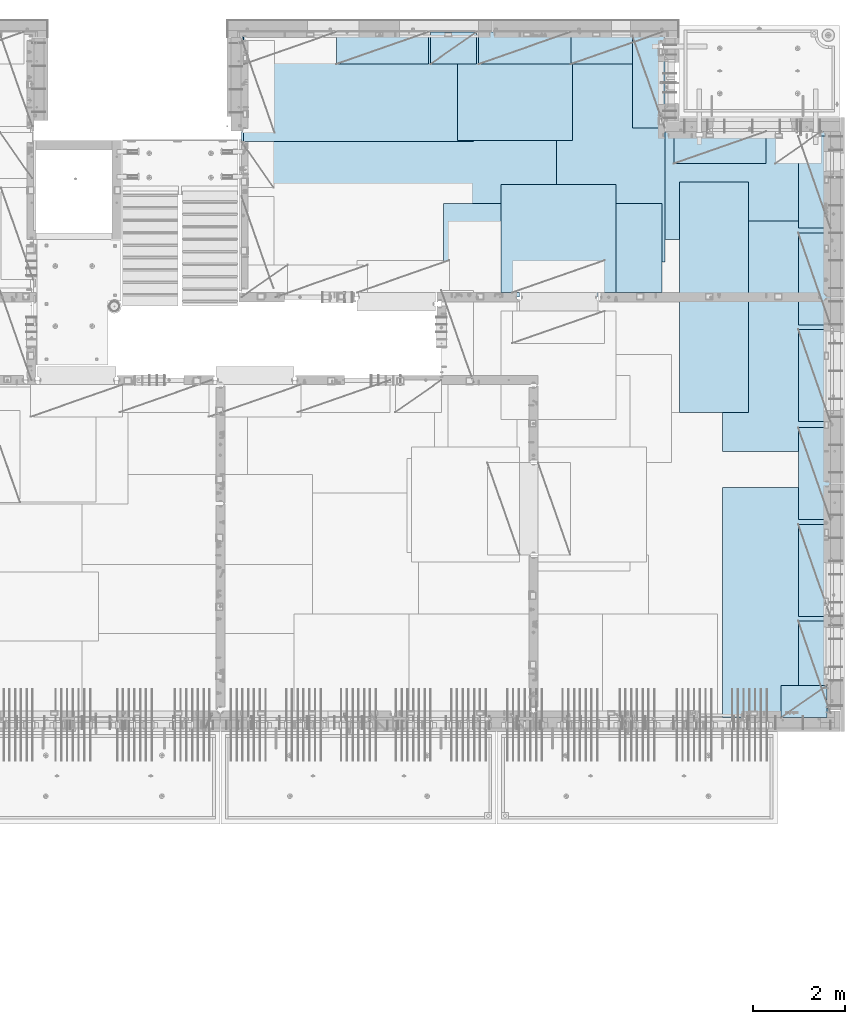
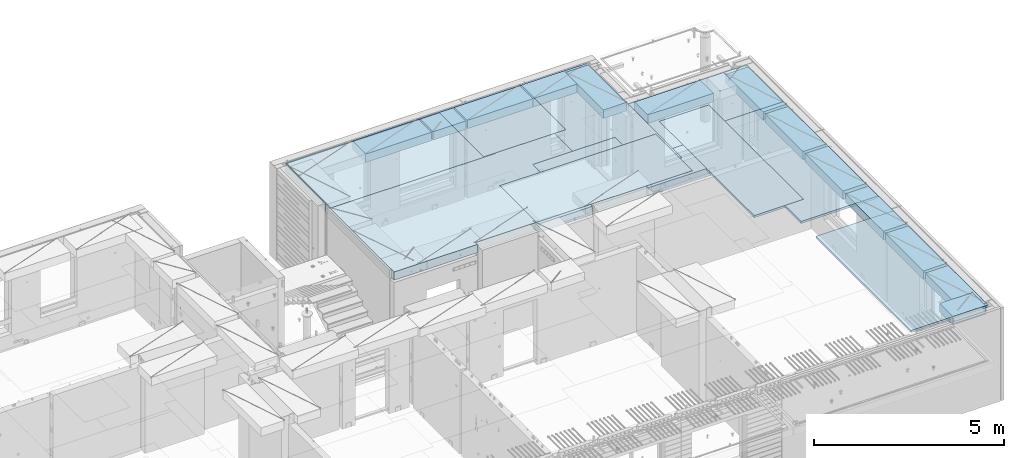
# One storey, part 201 of 334: 22 plates, 1 slab, 22 elements without a shape of their own.
"""IFC2X3 building model written with IfcOpenShell, lengths in millimetres."""

import ifcopenshell
import ifcopenshell.guid

model = None  # the IFC model being written
_history = None  # IfcOwnerHistory: only IFC2X3 demands one
_inside = {}  # id of a spatial element -> (the spatial element, [elements in it])
_under = {}  # id of a project, library or spatial element -> (it, [spatial elements below it])
_declared = {}  # id of a project -> (the project, [libraries it declares])
_typed = {}  # id of a type object -> (the type object, [elements of that type])
_made_of = {}  # id of a material, layer set ... -> (it, [elements and type objects made of it])


def new_model(schema):
    """Start an empty IFC model of exactly this schema.

    Asked for "IFC4X3", IfcOpenShell would pick the latest addendum, in which some entities
    have other attributes; the version numbers below select the first issue.
    IFC2X3 requires an IfcOwnerHistory on every rooted entity: one is made here for all.
    """
    global model, _history
    if schema == "IFC4X3":
        model = ifcopenshell.file(schema_version=(4, 3, 0, 0))
    else:
        model = ifcopenshell.file(schema=schema)
    _inside.clear()
    _under.clear()
    _declared.clear()
    _typed.clear()
    _made_of.clear()
    _history = None
    if model.schema == "IFC2X3":
        org = make("IfcOrganization", Name="unknown")
        user = make(
            "IfcPersonAndOrganization",
            ThePerson=make("IfcPerson", FamilyName="unknown"),
            TheOrganization=org,
        )
        app = make(
            "IfcApplication",
            ApplicationDeveloper=org,
            Version="unknown",
            ApplicationFullName="unknown",
            ApplicationIdentifier="unknown",
        )
        _history = make(
            "IfcOwnerHistory",
            OwningUser=user,
            OwningApplication=app,
            ChangeAction="ADDED",
            CreationDate=0,
        )
    return model


def make(cls, **values):
    """One entity of the class cls with the attributes given. An attribute that is None is left unset."""
    return model.create_entity(
        cls, **{name: value for name, value in values.items() if value is not None}
    )


def rooted(cls, **values):
    """An entity with a GlobalId (a new one), such as an element, a storey or a relation."""
    return make(cls, GlobalId=ifcopenshell.guid.new(), OwnerHistory=_history, **values)


def si_unit(unit_type, name, prefix=None):
    """IfcSIUnit, for example si_unit("LENGTHUNIT", "METRE", prefix="MILLI")."""
    return make("IfcSIUnit", UnitType=unit_type, Prefix=prefix, Name=name)


def assignment(units):
    """IfcUnitAssignment: the units of a project."""
    return None if units is None else make("IfcUnitAssignment", Units=units)


def point(xyz):
    """IfcCartesianPoint."""
    return None if xyz is None else make("IfcCartesianPoint", Coordinates=xyz)


def direction(xyz):
    """IfcDirection."""
    return None if xyz is None else make("IfcDirection", DirectionRatios=xyz)


def frame(location, z_axis=None, x_axis=None):
    """IfcAxis2Placement3D, a coordinate frame: its origin and axes. An axis left out is left unset."""
    return make(
        "IfcAxis2Placement3D",
        Location=point(location),
        Axis=direction(z_axis),
        RefDirection=direction(x_axis),
    )


def origin_with_axes():
    """The frame at (0, 0, 0) with the z axis (0, 0, 1) and the x axis (1, 0, 0) written out."""
    return frame((0.0, 0.0, 0.0), z_axis=(0.0, 0.0, 1.0), x_axis=(1.0, 0.0, 0.0))


def place(relative_to, where):
    """IfcLocalPlacement: puts the frame where relative to a parent placement (None: the world)."""
    return make(
        "IfcLocalPlacement", PlacementRelTo=relative_to, RelativePlacement=where
    )


def context(
    kind, dimensions, precision=None, world=None, true_north=None, identifier=None
):
    """IfcGeometricRepresentationContext, for example the 3D "Model" context."""
    return make(
        "IfcGeometricRepresentationContext",
        ContextIdentifier=identifier,
        ContextType=kind,
        CoordinateSpaceDimension=dimensions,
        Precision=precision,
        WorldCoordinateSystem=world,
        TrueNorth=true_north,
    )


def subcontext(parent, identifier, kind, view, scale=None):
    """IfcGeometricRepresentationSubContext, for example "Body" below "Model"."""
    return make(
        "IfcGeometricRepresentationSubContext",
        ContextIdentifier=identifier,
        ContextType=kind,
        ParentContext=parent,
        TargetScale=scale,
        TargetView=view,
    )


def project(units=None, contexts=None):
    """IfcProject with its units and contexts."""
    return rooted(
        "IfcProject",
        Name="project",
        RepresentationContexts=contexts,
        UnitsInContext=assignment(units),
    )


def spatial(cls, under=None, at=None, **own):
    """A site, building, storey or space (cls), placed at a placement, below another one or the project."""
    s = rooted(cls, ObjectPlacement=at, **own)
    if under is not None:
        _under.setdefault(under.id(), (under, []))[1].append(s)
    return s


def faces_of(points, faces, orient=None, outer=None):
    """IfcFace entities. A face is a list of loops; a loop is a list of indices into points, from 0.

    orient and outer hold one flag for each loop. By default every Orientation is true, the
    first loop of a face is its IfcFaceOuterBound and the others are IfcFaceBound.
    """
    made = []
    for i, loops in enumerate(faces):
        bounds = []
        for j, loop in enumerate(loops):
            is_outer = j == 0 if outer is None else outer[i][j]
            bounds.append(
                make(
                    "IfcFaceOuterBound" if is_outer else "IfcFaceBound",
                    Bound=make("IfcPolyLoop", Polygon=[points[k] for k in loop]),
                    Orientation=True if orient is None else orient[i][j],
                )
            )
        made.append(make("IfcFace", Bounds=bounds))
    return made


def faceted_brep(points, faces, orient=None, outer=None, voids=None):
    """IfcFacetedBrep: a solid bounded by flat faces; with voids (closed shells), ...WithVoids."""
    shared = [point(p) for p in points]
    hull = make("IfcClosedShell", CfsFaces=faces_of(shared, faces, orient, outer))
    if voids is None:
        return make("IfcFacetedBrep", Outer=hull)
    return make(
        "IfcFacetedBrepWithVoids",
        Outer=hull,
        Voids=[
            make(cls, CfsFaces=faces_of(shared, fs, o, b)) for cls, fs, o, b in voids
        ],
    )


def shape(context_of_items, identifier, shape_type, items):
    """IfcShapeRepresentation: the items that make up one representation, for example the "Body"."""
    return make(
        "IfcShapeRepresentation",
        ContextOfItems=context_of_items,
        RepresentationIdentifier=identifier,
        RepresentationType=shape_type,
        Items=items,
    )


def material(Name=None, Category=None):
    """IfcMaterial."""
    return make("IfcMaterial", Name=Name, Category=Category)


def made_of(thing, what):
    """Note that an element or type object is made of a material, layer set ...; save() writes the relation."""
    if what is not None:
        _made_of.setdefault(what.id(), (what, []))[1].append(thing)
    return thing


def type_object(cls, material=None, **own):
    """A type object (cls), such as IfcWallType, which elements share."""
    return made_of(rooted(cls, **own), material)


def element(
    cls,
    number,
    at=None,
    inside=None,
    cuts=None,
    type_object=None,
    material=None,
    context=None,
    identifier="Body",
    shape_type=None,
    held_by="IfcProductDefinitionShape",
    body=None,
    shapes=None,
    **own,
):
    """One element of the class cls, such as IfcWall. Its Tag is "e" and its number.

    at: its placement. inside: the storey or other place that contains it. cuts: it is an
    opening in that element (IfcRelVoidsElement). A single representation is given by context,
    identifier, shape_type and body (its items); several are given by shapes. held_by: the class
    of the entity that holds the representations. save() writes the other relations.
    """
    e = rooted(cls, Tag="e%d" % number, ObjectPlacement=at, **own)
    if body is not None:
        shapes = [shape(context, identifier, shape_type, body)]
    if shapes is not None:
        e.Representation = make(held_by, Representations=shapes)
    if inside is not None:
        _inside.setdefault(inside.id(), (inside, []))[1].append(e)
    if cuts is not None:
        rooted(
            "IfcRelVoidsElement", RelatingBuildingElement=cuts, RelatedOpeningElement=e
        )
    if type_object is not None:
        _typed.setdefault(type_object.id(), (type_object, []))[1].append(e)
    return made_of(e, material)


def aggregate(whole, parts):
    """IfcRelAggregates: a whole, such as a stair, and the parts it consists of."""
    return rooted("IfcRelAggregates", RelatingObject=whole, RelatedObjects=parts)


def save(model, path):
    """Write the relations noted so far, then the file.

    IfcRelAggregates (storeys below a building ...), IfcRelContainedInSpatialStructure (elements
    in a storey), IfcRelDefinesByType, IfcRelAssociatesMaterial and IfcRelDeclares: one each for
    every whole, place, type object, material and project.
    """
    for whole, parts in _under.values():
        aggregate(whole, parts)
    for where, things in _inside.values():
        rooted(
            "IfcRelContainedInSpatialStructure",
            RelatedElements=things,
            RelatingStructure=where,
        )
    for kind, things in _typed.values():
        rooted("IfcRelDefinesByType", RelatedObjects=things, RelatingType=kind)
    for what, things in _made_of.values():
        rooted("IfcRelAssociatesMaterial", RelatedObjects=things, RelatingMaterial=what)
    for by, libraries in _declared.values():
        rooted("IfcRelDeclares", RelatingContext=by, RelatedDefinitions=libraries)
    model.write(path)


model = new_model("IFC2X3")

# Units and contexts
model_context = context("Model", 3, precision=1e-05, world=origin_with_axes())
body_context = subcontext(model_context, "Body", "Model", "MODEL_VIEW")
ifc_project = project(units=[si_unit("LENGTHUNIT", "METRE", prefix="MILLI"), si_unit("AREAUNIT", "SQUARE_METRE"), si_unit("VOLUMEUNIT", "CUBIC_METRE"), si_unit("MASSUNIT", "GRAM", prefix="KILO"), si_unit("TIMEUNIT", "SECOND"), si_unit("PLANEANGLEUNIT", "RADIAN"), si_unit("SOLIDANGLEUNIT", "STERADIAN"), si_unit("THERMODYNAMICTEMPERATUREUNIT", "DEGREE_CELSIUS"), si_unit("LUMINOUSINTENSITYUNIT", "LUMEN")], contexts=[model_context])

# Site, building, storey
site_placement = place(None, origin_with_axes())
site = spatial("IfcSite", under=ifc_project, at=site_placement, CompositionType="ELEMENT")
building_placement = place(site_placement, origin_with_axes())
building = spatial("IfcBuilding", under=site, at=building_placement, CompositionType="ELEMENT")
storey_placement = place(building_placement, origin_with_axes())
storey = spatial("IfcBuildingStorey", under=building, at=storey_placement, Name="3", CompositionType="ELEMENT", Elevation=0.0)

# Assembly, slab
assembly_1_placement = place(storey_placement, origin_with_axes())
assembly_1 = element("IfcElementAssembly", 1, at=assembly_1_placement, inside=storey, AssemblyPlace="NOTDEFINED", PredefinedType="REINFORCEMENT_UNIT")
ifc_material_1 = material(Name="CONCRETE/C30/37")
slab_type = type_object("IfcSlabType", PredefinedType="NOTDEFINED")
slab_placement = place(assembly_1_placement, frame((22310.0, 16980.0, 90595.0), z_axis=(0.0, 1.0, 0.0), x_axis=(1.0, 0.0, 0.0)))
slab = element("IfcSlab", 2, at=slab_placement, type_object=slab_type, material=ifc_material_1, PredefinedType="FLOOR", context=body_context, shape_type="Brep", body=[
    faceted_brep([(2489.99914550781, -135.0, 0.0), (2489.99914550781, 135.0, 0.0), (2489.99914550781, 135.0, 99.9997253417969), (2489.99914550781, -135.0, 99.9997253417969), (2730.00000000001, -135.0, 99.9999987875526), (2730.00000000001, 135.0, 99.9999987875526), (1.81898940354586e-12, -135.0, 1.81898940354586e-12), (-39.9985427856445, -135.0, -0.0037095642182976), (-39.9985427856445, 135.0, -0.0037095642182976), (1.81898940354586e-12, 135.0, 1.81898940354586e-12), (-40.0, -135.0, 3600.00048828125), (-40.0, 135.0, 3600.00048828125), (-20.0, -135.0, 3600.0), (-20.0, 135.0, 3600.0), (-20.0, -135.0, 5760.0), (-20.0, 135.0, 5760.0), (9149.9990234375, -135.0, 5760.0), (9149.9990234375, 135.0, 5760.0), (9149.9990234375, -135.0, 3600.00073242188), (9149.9990234375, 135.0, 3600.00073242188), (12750.0, -135.0, 3599.9951171875), (12750.0, 135.0, 3599.9951171875), (12750.0, -135.0, 0.0), (12750.0, 135.0, 0.0), (7685.00027673977, -135.0, 0.0), (7685.00027673977, 135.0, 0.0), (7685.00027673977, -135.0, 99.9997241293495), (7685.00027673977, 135.0, 99.9997241293495), (6000.00027673977, -135.0, 99.9997241293495), (6000.00027673977, 135.0, 99.9997241293495), (6000.00027673977, -135.0, 0.0), (6000.00027673977, 135.0, 0.0), (4369.99914550782, -135.0, 0.0), (4369.99914550782, 135.0, 0.0), (4369.99914550782, -135.0, 99.9999987875526), (4369.99914550782, 135.0, 99.9999987875526), (4169.99914550781, -135.0, 99.9999987875526), (4169.99914550781, 135.0, 99.9999987875526)], [[[0, 1, 2, 3]], [[4, 3, 2, 5]], [[6, 7, 8, 9]], [[7, 10, 11, 8]], [[10, 12, 13, 11]], [[12, 14, 15, 13]], [[14, 16, 17, 15]], [[16, 18, 19, 17]], [[18, 20, 21, 19]], [[20, 22, 23, 21]], [[23, 22, 24, 25]], [[26, 27, 25, 24]], [[28, 29, 27, 26]], [[30, 31, 29, 28]], [[31, 30, 32, 33]], [[34, 35, 33, 32]], [[36, 4, 5, 37, 35, 34]], [[1, 9, 8, 11, 13, 15, 17, 19, 21, 23, 25, 27, 29, 31, 33, 35, 37, 5, 2]], [[6, 9, 1, 0]], [[36, 34, 32, 30, 28, 26, 24, 22, 20, 18, 16, 14, 12, 10, 7, 6, 0, 3, 4]]]),
])

# Assembly, plate
assembly_2_placement = place(storey_placement, origin_with_axes())
assembly_2 = element("IfcElementAssembly", 3, at=assembly_2_placement, inside=storey, Name="Steel Assembly", AssemblyPlace="NOTDEFINED", PredefinedType="NOTDEFINED")
ifc_material_2 = material()
plate_type_1 = type_object("IfcPlateType", PredefinedType="NOTDEFINED")
plate_1_placement = place(assembly_2_placement, frame((26960.07, 22728.45, 90695.1), z_axis=(1.0, 0.0, 0.0), x_axis=(0.0, -1.0, 0.0)))
plate_1 = element("IfcPlate", 4, at=plate_1_placement, type_object=plate_type_1, material=ifc_material_2, Name="1/2", context=body_context, shape_type="Brep", body=[
    faceted_brep([(0.0, -35.0, 0.0), (0.0, -35.0, 2500.0), (0.0, 35.0, 2500.0), (0.0, 35.0, 0.0), (2349.99951171875, -35.0, 2500.0), (2349.99951171875, 35.0, 2500.0), (2350.0, -35.0, 0.0), (2350.0, 35.0, 0.0)], [[[0, 1, 2, 3]], [[1, 4, 5, 2]], [[4, 6, 7, 5]], [[6, 0, 3, 7]], [[5, 7, 3, 2]], [[6, 4, 1, 0]]]),
])
aggregate(assembly_2, [plate_1])

assembly_3_placement = place(storey_placement, origin_with_axes())
assembly_3 = element("IfcElementAssembly", 5, at=assembly_3_placement, inside=storey, Name="Steel Assembly", AssemblyPlace="NOTDEFINED", PredefinedType="NOTDEFINED")
plate_2_placement = place(assembly_3_placement, frame((22309.9998779297, 22710.0009765625, 90695.1), z_axis=(1.0, 0.0, 0.0), x_axis=(0.0, -1.0, 0.0)))
plate_2 = element("IfcPlate", 6, at=plate_2_placement, type_object=plate_type_1, material=ifc_material_2, context=body_context, shape_type="Brep", body=[
    faceted_brep([(0.0, -35.0, 0.0), (0.0, -35.0, 5000.0), (0.0, 35.0, 5000.0), (0.0, 35.0, 0.0), (2349.99951171875, -35.0, 5000.0), (2349.99951171875, 35.0, 5000.0), (2350.0, -35.0, 0.0), (2350.0, 35.0, 0.0)], [[[0, 1, 2, 3]], [[1, 4, 5, 2]], [[4, 6, 7, 5]], [[6, 0, 3, 7]], [[5, 7, 3, 2]], [[6, 4, 1, 0]]]),
])
aggregate(assembly_3, [plate_2])

assembly_4_placement = place(storey_placement, origin_with_axes())
assembly_4 = element("IfcElementAssembly", 7, at=assembly_4_placement, inside=storey, Name="Steel Assembly", AssemblyPlace="NOTDEFINED", PredefinedType="NOTDEFINED")
plate_3_placement = place(assembly_4_placement, frame((27902.5, 19430.0, 90695.1), z_axis=(1.0, 0.0, 0.0), x_axis=(0.0, -1.0, 0.0)))
plate_3 = element("IfcPlate", 8, at=plate_3_placement, type_object=plate_type_1, material=ifc_material_2, Name="1/2", context=body_context, shape_type="Brep", body=[
    faceted_brep([(0.0, -35.0, 0.0), (0.0, -35.0, 2500.0), (0.0, 35.0, 2500.0), (0.0, 35.0, 0.0), (2349.99951171875, -35.0, 2500.0), (2349.99951171875, 35.0, 2500.0), (2350.0, -35.0, 0.0), (2350.0, 35.0, 0.0)], [[[0, 1, 2, 3]], [[1, 4, 5, 2]], [[4, 6, 7, 5]], [[6, 0, 3, 7]], [[5, 7, 3, 2]], [[6, 4, 1, 0]]]),
])
aggregate(assembly_4, [plate_3])

assembly_5_placement = place(storey_placement, origin_with_axes())
assembly_5 = element("IfcElementAssembly", 9, at=assembly_5_placement, inside=storey, Name="Steel Assembly", AssemblyPlace="NOTDEFINED", PredefinedType="NOTDEFINED")
plate_4_placement = place(assembly_5_placement, frame((31460.0, 22740.0, 90695.1), z_axis=(0.0, -1.0, 0.0), x_axis=(-1.0, 3.00000001838171e-08, 0.0)))
plate_4 = element("IfcPlate", 10, at=plate_4_placement, type_object=plate_type_1, material=ifc_material_2, context=body_context, shape_type="Brep", body=[
    faceted_brep([(0.0, -35.0, 0.0), (0.0, -35.0, 5000.0), (0.0, 35.0, 5000.0), (0.0, 35.0, 0.0), (2349.99951171875, -35.0, 5000.0), (2349.99951171875, 35.0, 5000.0), (2350.0, -35.0, 0.0), (2350.0, 35.0, 0.0)], [[[0, 1, 2, 3]], [[1, 4, 5, 2]], [[4, 6, 7, 5]], [[6, 0, 3, 7]], [[5, 7, 3, 2]], [[6, 4, 1, 0]]]),
])
aggregate(assembly_5, [plate_4])

assembly_6_placement = place(storey_placement, origin_with_axes())
assembly_6 = element("IfcElementAssembly", 11, at=assembly_6_placement, inside=storey, Name="Steel Assembly", AssemblyPlace="NOTDEFINED", PredefinedType="NOTDEFINED")
plate_5_placement = place(assembly_6_placement, frame((35060.0, 12850.0, 90695.1), z_axis=(0.0, -1.0, 0.0), x_axis=(-1.0, 3.00000001838171e-08, 0.0)))
plate_5 = element("IfcPlate", 12, at=plate_5_placement, type_object=plate_type_1, material=ifc_material_2, context=body_context, shape_type="Brep", body=[
    faceted_brep([(0.0, -35.0, 0.0), (0.0, -35.0, 5000.0), (0.0, 35.0, 5000.0), (0.0, 35.0, 0.0), (2349.99951171875, -35.0, 5000.0), (2349.99951171875, 35.0, 5000.0), (2350.0, -35.0, 0.0), (2350.0, 35.0, 0.0)], [[[0, 1, 2, 3]], [[1, 4, 5, 2]], [[4, 6, 7, 5]], [[6, 0, 3, 7]], [[5, 7, 3, 2]], [[6, 4, 1, 0]]]),
])
aggregate(assembly_6, [plate_5])

assembly_7_placement = place(storey_placement, origin_with_axes())
assembly_7 = element("IfcElementAssembly", 13, at=assembly_7_placement, inside=storey, Name="Steel Assembly", AssemblyPlace="NOTDEFINED", PredefinedType="NOTDEFINED")
plate_6_placement = place(assembly_7_placement, frame((35060.0, 18630.0, 90695.1), z_axis=(0.0, -1.0, 0.0), x_axis=(-1.0, 3.00000001838171e-08, 0.0)))
plate_6 = element("IfcPlate", 14, at=plate_6_placement, type_object=plate_type_1, material=ifc_material_2, context=body_context, shape_type="Brep", body=[
    faceted_brep([(0.0, -35.0, 0.0), (0.0, -35.0, 5000.0), (0.0, 35.0, 5000.0), (0.0, 35.0, 0.0), (2349.99951171875, -35.0, 5000.0), (2349.99951171875, 35.0, 5000.0), (2350.0, -35.0, 0.0), (2350.0, 35.0, 0.0)], [[[0, 1, 2, 3]], [[1, 4, 5, 2]], [[4, 6, 7, 5]], [[6, 0, 3, 7]], [[5, 7, 3, 2]], [[6, 4, 1, 0]]]),
])
aggregate(assembly_7, [plate_6])

assembly_8_placement = place(storey_placement, origin_with_axes())
assembly_8 = element("IfcElementAssembly", 15, at=assembly_8_placement, inside=storey, Name="Steel Assembly", AssemblyPlace="NOTDEFINED", PredefinedType="NOTDEFINED")
plate_7_placement = place(assembly_8_placement, frame((30060.0, 20580.0, 90695.1), z_axis=(1.0, 0.0, 0.0), x_axis=(0.0, -1.0, 0.0)))
plate_7 = element("IfcPlate", 16, at=plate_7_placement, type_object=plate_type_1, material=ifc_material_2, context=body_context, shape_type="Brep", body=[
    faceted_brep([(0.0, -35.0, 0.0), (0.0, -35.0, 5000.0), (0.0, 35.0, 5000.0), (0.0, 35.0, 0.0), (2349.99951171875, -35.0, 5000.0), (2349.99951171875, 35.0, 5000.0), (2350.0, -35.0, 0.0), (2350.0, 35.0, 0.0)], [[[0, 1, 2, 3]], [[1, 4, 5, 2]], [[4, 6, 7, 5]], [[6, 0, 3, 7]], [[5, 7, 3, 2]], [[6, 4, 1, 0]]]),
])
aggregate(assembly_8, [plate_7])

assembly_9_placement = place(storey_placement, origin_with_axes())
assembly_9 = element("IfcElementAssembly", 17, at=assembly_9_placement, inside=storey, Name="Steel Assembly", AssemblyPlace="NOTDEFINED", PredefinedType="NOTDEFINED")
plate_type_2 = type_object("IfcPlateType", PredefinedType="NOTDEFINED")
plate_8_placement = place(assembly_9_placement, frame((33275.0000122641, 19480.0, 90695.1000003815), z_axis=(0.0, -1.0, 0.0), x_axis=(-1.0, 3.00000001838171e-08, 0.0)))
plate_8 = element("IfcPlate", 18, at=plate_8_placement, type_object=plate_type_2, material=ifc_material_2, context=body_context, shape_type="Brep", body=[
    faceted_brep([(0.0, -35.0, 0.0), (0.0, -35.0, 5000.0), (0.0, 35.0, 5000.0), (0.0, 35.0, 0.0), (1499.99951171875, -35.0, 5000.0), (1499.99951171875, 35.0, 5000.0), (1500.0, -35.0, 0.0), (1500.0, 35.0, 0.0)], [[[0, 1, 2, 3]], [[1, 4, 5, 2]], [[4, 6, 7, 5]], [[6, 0, 3, 7]], [[5, 7, 3, 2]], [[6, 4, 1, 0]]]),
])
aggregate(assembly_9, [plate_8])

assembly_10_placement = place(storey_placement, origin_with_axes())
assembly_10 = element("IfcElementAssembly", 19, at=assembly_10_placement, inside=storey, Name="Steel Assembly", AssemblyPlace="NOTDEFINED", PredefinedType="NOTDEFINED")
plate_type_3 = type_object("IfcPlateType", PredefinedType="NOTDEFINED")
plate_9_placement = place(assembly_10_placement, frame((31420.0, 22740.0001220703, 90595.3), z_axis=(0.0, -1.0, 0.0), x_axis=(-1.0, 3.00000001838171e-08, 0.0)))
plate_9 = element("IfcPlate", 20, at=plate_9_placement, type_object=plate_type_3, material=ifc_material_2, Name="RE1", context=body_context, shape_type="Brep", body=[
    faceted_brep([(1.81898940354586e-12, -135.0, 1.81898940354586e-12), (0.0, -135.0, 699.999999999996), (0.0, 135.0, 699.999999999996), (1.81898940354586e-12, 135.0, 1.81898940354586e-12), (1999.99951171875, -135.0, 699.999999999993), (1999.99951171875, 135.0, 699.999999999993), (2000.0, -135.0, -3.63797880709171e-12), (2000.0, 135.0, -3.63797880709171e-12)], [[[0, 1, 2, 3]], [[1, 4, 5, 2]], [[4, 6, 7, 5]], [[6, 0, 3, 7]], [[5, 7, 3, 2]], [[6, 4, 1, 0]]]),
])
aggregate(assembly_10, [plate_9])

assembly_11_placement = place(storey_placement, origin_with_axes())
assembly_11 = element("IfcElementAssembly", 21, at=assembly_11_placement, inside=storey, Name="Steel Assembly", AssemblyPlace="NOTDEFINED", PredefinedType="NOTDEFINED")
plate_10_placement = place(assembly_11_placement, frame((33985.0, 7849.99999992931, 90595.3), z_axis=(0.0, 1.0, 0.0), x_axis=(1.0, 0.0, 0.0)))
plate_10 = element("IfcPlate", 22, at=plate_10_placement, type_object=plate_type_3, material=ifc_material_2, Name="RE1_1/2", context=body_context, shape_type="Brep", body=[
    faceted_brep([(1.81898940354586e-12, -135.0, 1.81898940354586e-12), (0.0, -135.0, 699.999999999996), (0.0, 135.0, 699.999999999996), (1.81898940354586e-12, 135.0, 1.81898940354586e-12), (999.99951171875, -135.0, 700.0), (999.99951171875, 135.0, 700.0), (1000.0, -135.0, 0.0), (1000.0, 135.0, 0.0)], [[[0, 1, 2, 3]], [[1, 4, 5, 2]], [[4, 6, 7, 5]], [[6, 0, 3, 7]], [[5, 7, 3, 2]], [[6, 4, 1, 0]]]),
])
aggregate(assembly_11, [plate_10])

assembly_12_placement = place(storey_placement, origin_with_axes())
assembly_12 = element("IfcElementAssembly", 23, at=assembly_12_placement, inside=storey, Name="Steel Assembly", AssemblyPlace="NOTDEFINED", PredefinedType="NOTDEFINED")
plate_11_placement = place(assembly_12_placement, frame((35060.0001220703, 14280.0, 90595.3), z_axis=(-1.0, 3.00000001838171e-08, 0.0), x_axis=(0.0, 1.0, 0.0)))
plate_11 = element("IfcPlate", 24, at=plate_11_placement, type_object=plate_type_3, material=ifc_material_2, Name="RE1", context=body_context, shape_type="Brep", body=[
    faceted_brep([(1.81898940354586e-12, -135.0, 1.81898940354586e-12), (0.0, -135.0, 699.999999999996), (0.0, 135.0, 699.999999999996), (1.81898940354586e-12, 135.0, 1.81898940354586e-12), (1999.99951171875, -135.0, 699.999999999993), (1999.99951171875, 135.0, 699.999999999993), (2000.0, -135.0, -3.63797880709171e-12), (2000.0, 135.0, -3.63797880709171e-12)], [[[0, 1, 2, 3]], [[1, 4, 5, 2]], [[4, 6, 7, 5]], [[6, 0, 3, 7]], [[5, 7, 3, 2]], [[6, 4, 1, 0]]]),
])
aggregate(assembly_12, [plate_11])

assembly_13_placement = place(storey_placement, origin_with_axes())
assembly_13 = element("IfcElementAssembly", 25, at=assembly_13_placement, inside=storey, Name="Steel Assembly", AssemblyPlace="NOTDEFINED", PredefinedType="NOTDEFINED")
plate_12_placement = place(assembly_13_placement, frame((35060.0001220703, 16380.0, 90595.3), z_axis=(-1.0, 3.00000001838171e-08, 0.0), x_axis=(0.0, 1.0, 0.0)))
plate_12 = element("IfcPlate", 26, at=plate_12_placement, type_object=plate_type_3, material=ifc_material_2, Name="RE1", context=body_context, shape_type="Brep", body=[
    faceted_brep([(1.81898940354586e-12, -135.0, 1.81898940354586e-12), (0.0, -135.0, 699.999999999996), (0.0, 135.0, 699.999999999996), (1.81898940354586e-12, 135.0, 1.81898940354586e-12), (1999.99951171875, -135.0, 699.999999999993), (1999.99951171875, 135.0, 699.999999999993), (2000.0, -135.0, -3.63797880709171e-12), (2000.0, 135.0, -3.63797880709171e-12)], [[[0, 1, 2, 3]], [[1, 4, 5, 2]], [[4, 6, 7, 5]], [[6, 0, 3, 7]], [[5, 7, 3, 2]], [[6, 4, 1, 0]]]),
])
aggregate(assembly_13, [plate_12])

assembly_14_placement = place(storey_placement, origin_with_axes())
assembly_14 = element("IfcElementAssembly", 27, at=assembly_14_placement, inside=storey, Name="Steel Assembly", AssemblyPlace="NOTDEFINED", PredefinedType="NOTDEFINED")
plate_13_placement = place(assembly_14_placement, frame((35060.0001220703, 18480.0, 90595.3), z_axis=(-1.0, 3.00000001838171e-08, 0.0), x_axis=(0.0, 1.0, 0.0)))
plate_13 = element("IfcPlate", 28, at=plate_13_placement, type_object=plate_type_3, material=ifc_material_2, Name="RE1", context=body_context, shape_type="Brep", body=[
    faceted_brep([(1.81898940354586e-12, -135.0, 1.81898940354586e-12), (0.0, -135.0, 699.999999999996), (0.0, 135.0, 699.999999999996), (1.81898940354586e-12, 135.0, 1.81898940354586e-12), (1999.99951171875, -135.0, 699.999999999993), (1999.99951171875, 135.0, 699.999999999993), (2000.0, -135.0, -3.63797880709171e-12), (2000.0, 135.0, -3.63797880709171e-12)], [[[0, 1, 2, 3]], [[1, 4, 5, 2]], [[4, 6, 7, 5]], [[6, 0, 3, 7]], [[5, 7, 3, 2]], [[6, 4, 1, 0]]]),
])
aggregate(assembly_14, [plate_13])

assembly_15_placement = place(storey_placement, origin_with_axes())
assembly_15 = element("IfcElementAssembly", 29, at=assembly_15_placement, inside=storey, Name="Steel Assembly", AssemblyPlace="NOTDEFINED", PredefinedType="NOTDEFINED")
plate_14_placement = place(assembly_15_placement, frame((35060.0001220703, 12150.0, 90595.3), z_axis=(-1.0, 3.00000001838171e-08, 0.0), x_axis=(0.0, 1.0, 0.0)))
plate_14 = element("IfcPlate", 30, at=plate_14_placement, type_object=plate_type_3, material=ifc_material_2, Name="RE1", context=body_context, shape_type="Brep", body=[
    faceted_brep([(1.81898940354586e-12, -135.0, 1.81898940354586e-12), (0.0, -135.0, 699.999999999996), (0.0, 135.0, 699.999999999996), (1.81898940354586e-12, 135.0, 1.81898940354586e-12), (1999.99951171875, -135.0, 699.999999999993), (1999.99951171875, 135.0, 699.999999999993), (2000.0, -135.0, -3.63797880709171e-12), (2000.0, 135.0, -3.63797880709171e-12)], [[[0, 1, 2, 3]], [[1, 4, 5, 2]], [[4, 6, 7, 5]], [[6, 0, 3, 7]], [[5, 7, 3, 2]], [[6, 4, 1, 0]]]),
])
aggregate(assembly_15, [plate_14])

assembly_16_placement = place(storey_placement, origin_with_axes())
assembly_16 = element("IfcElementAssembly", 31, at=assembly_16_placement, inside=storey, Name="Steel Assembly", AssemblyPlace="NOTDEFINED", PredefinedType="NOTDEFINED")
plate_15_placement = place(assembly_16_placement, frame((35060.0001220703, 10050.0, 90595.3), z_axis=(-1.0, 3.00000001838171e-08, 0.0), x_axis=(0.0, 1.0, 0.0)))
plate_15 = element("IfcPlate", 32, at=plate_15_placement, type_object=plate_type_3, material=ifc_material_2, Name="RE1", context=body_context, shape_type="Brep", body=[
    faceted_brep([(1.81898940354586e-12, -135.0, 1.81898940354586e-12), (0.0, -135.0, 699.999999999996), (0.0, 135.0, 699.999999999996), (1.81898940354586e-12, 135.0, 1.81898940354586e-12), (1999.99951171875, -135.0, 699.999999999993), (1999.99951171875, 135.0, 699.999999999993), (2000.0, -135.0, -3.63797880709171e-12), (2000.0, 135.0, -3.63797880709171e-12)], [[[0, 1, 2, 3]], [[1, 4, 5, 2]], [[4, 6, 7, 5]], [[6, 0, 3, 7]], [[5, 7, 3, 2]], [[6, 4, 1, 0]]]),
])
aggregate(assembly_16, [plate_15])

assembly_17_placement = place(storey_placement, origin_with_axes())
assembly_17 = element("IfcElementAssembly", 33, at=assembly_17_placement, inside=storey, Name="Steel Assembly", AssemblyPlace="NOTDEFINED", PredefinedType="NOTDEFINED")
plate_16_placement = place(assembly_17_placement, frame((35060.0001220703, 7950.0, 90595.3), z_axis=(-1.0, 3.00000001838171e-08, 0.0), x_axis=(0.0, 1.0, 0.0)))
plate_16 = element("IfcPlate", 34, at=plate_16_placement, type_object=plate_type_3, material=ifc_material_2, Name="RE1", context=body_context, shape_type="Brep", body=[
    faceted_brep([(1.81898940354586e-12, -135.0, 1.81898940354586e-12), (0.0, -135.0, 699.999999999996), (0.0, 135.0, 699.999999999996), (1.81898940354586e-12, 135.0, 1.81898940354586e-12), (1999.99951171875, -135.0, 699.999999999993), (1999.99951171875, 135.0, 699.999999999993), (2000.0, -135.0, -3.63797880709171e-12), (2000.0, 135.0, -3.63797880709171e-12)], [[[0, 1, 2, 3]], [[1, 4, 5, 2]], [[4, 6, 7, 5]], [[6, 0, 3, 7]], [[5, 7, 3, 2]], [[6, 4, 1, 0]]]),
])
aggregate(assembly_17, [plate_16])

assembly_18_placement = place(storey_placement, origin_with_axes())
assembly_18 = element("IfcElementAssembly", 35, at=assembly_18_placement, inside=storey, Name="Steel Assembly", AssemblyPlace="NOTDEFINED", PredefinedType="NOTDEFINED")
plate_17_placement = place(assembly_18_placement, frame((33660.0, 20580.0001220703, 90595.3), z_axis=(0.0, -1.0, 0.0), x_axis=(-1.0, 3.00000001838171e-08, 0.0)))
plate_17 = element("IfcPlate", 36, at=plate_17_placement, type_object=plate_type_3, material=ifc_material_2, Name="RE1", context=body_context, shape_type="Brep", body=[
    faceted_brep([(1.81898940354586e-12, -135.0, 1.81898940354586e-12), (0.0, -135.0, 699.999999999996), (0.0, 135.0, 699.999999999996), (1.81898940354586e-12, 135.0, 1.81898940354586e-12), (1999.99951171875, -135.0, 699.999999999993), (1999.99951171875, 135.0, 699.999999999993), (2000.0, -135.0, -3.63797880709171e-12), (2000.0, 135.0, -3.63797880709171e-12)], [[[0, 1, 2, 3]], [[1, 4, 5, 2]], [[4, 6, 7, 5]], [[6, 0, 3, 7]], [[5, 7, 3, 2]], [[6, 4, 1, 0]]]),
])
aggregate(assembly_18, [plate_17])

assembly_19_placement = place(storey_placement, origin_with_axes())
assembly_19 = element("IfcElementAssembly", 37, at=assembly_19_placement, inside=storey, Name="Steel Assembly", AssemblyPlace="NOTDEFINED", PredefinedType="NOTDEFINED")
plate_18_placement = place(assembly_19_placement, frame((31460.0001220703, 20660.0, 90595.3), z_axis=(-1.0, 3.00000001838171e-08, 0.0), x_axis=(0.0, 1.0, 0.0)))
plate_18 = element("IfcPlate", 38, at=plate_18_placement, type_object=plate_type_3, material=ifc_material_2, Name="RE1", context=body_context, shape_type="Brep", body=[
    faceted_brep([(1.81898940354586e-12, -135.0, 1.81898940354586e-12), (0.0, -135.0, 699.999999999996), (0.0, 135.0, 699.999999999996), (1.81898940354586e-12, 135.0, 1.81898940354586e-12), (1999.99951171875, -135.0, 699.999999999993), (1999.99951171875, 135.0, 699.999999999993), (2000.0, -135.0, -3.63797880709171e-12), (2000.0, 135.0, -3.63797880709171e-12)], [[[0, 1, 2, 3]], [[1, 4, 5, 2]], [[4, 6, 7, 5]], [[6, 0, 3, 7]], [[5, 7, 3, 2]], [[6, 4, 1, 0]]]),
])
aggregate(assembly_19, [plate_18])

assembly_20_placement = place(storey_placement, origin_with_axes())
assembly_20 = element("IfcElementAssembly", 39, at=assembly_20_placement, inside=storey, Name="Steel Assembly", AssemblyPlace="NOTDEFINED", PredefinedType="NOTDEFINED")
plate_19_placement = place(assembly_20_placement, frame((26330.0, 22740.0001220703, 90595.3), z_axis=(0.0, -1.0, 0.0), x_axis=(-1.0, 3.00000001838171e-08, 0.0)))
plate_19 = element("IfcPlate", 40, at=plate_19_placement, type_object=plate_type_3, material=ifc_material_2, Name="RE1", context=body_context, shape_type="Brep", body=[
    faceted_brep([(1.81898940354586e-12, -135.0, 1.81898940354586e-12), (0.0, -135.0, 699.999999999996), (0.0, 135.0, 699.999999999996), (1.81898940354586e-12, 135.0, 1.81898940354586e-12), (1999.99951171875, -135.0, 699.999999999993), (1999.99951171875, 135.0, 699.999999999993), (2000.0, -135.0, -3.63797880709171e-12), (2000.0, 135.0, -3.63797880709171e-12)], [[[0, 1, 2, 3]], [[1, 4, 5, 2]], [[4, 6, 7, 5]], [[6, 0, 3, 7]], [[5, 7, 3, 2]], [[6, 4, 1, 0]]]),
])
aggregate(assembly_20, [plate_19])

assembly_21_placement = place(storey_placement, origin_with_axes())
assembly_21 = element("IfcElementAssembly", 41, at=assembly_21_placement, inside=storey, Name="Steel Assembly", AssemblyPlace="NOTDEFINED", PredefinedType="NOTDEFINED")
plate_20_placement = place(assembly_21_placement, frame((29420.0, 22740.0001220703, 90595.3), z_axis=(0.0, -1.0, 0.0), x_axis=(-1.0, 3.00000001838171e-08, 0.0)))
plate_20 = element("IfcPlate", 42, at=plate_20_placement, type_object=plate_type_3, material=ifc_material_2, Name="RE1", context=body_context, shape_type="Brep", body=[
    faceted_brep([(1.81898940354586e-12, -135.0, 1.81898940354586e-12), (0.0, -135.0, 699.999999999996), (0.0, 135.0, 699.999999999996), (1.81898940354586e-12, 135.0, 1.81898940354586e-12), (1999.99951171875, -135.0, 699.999999999993), (1999.99951171875, 135.0, 699.999999999993), (2000.0, -135.0, -3.63797880709171e-12), (2000.0, 135.0, -3.63797880709171e-12)], [[[0, 1, 2, 3]], [[1, 4, 5, 2]], [[4, 6, 7, 5]], [[6, 0, 3, 7]], [[5, 7, 3, 2]], [[6, 4, 1, 0]]]),
])
aggregate(assembly_21, [plate_20])

assembly_22_placement = place(storey_placement, origin_with_axes())
assembly_22 = element("IfcElementAssembly", 43, at=assembly_22_placement, inside=storey, Name="Steel Assembly", AssemblyPlace="NOTDEFINED", PredefinedType="NOTDEFINED")
plate_21_placement = place(assembly_22_placement, frame((27375.0, 22740.0000000707, 90595.3), z_axis=(0.0, -1.0, 0.0), x_axis=(-1.0, 3.00000001838171e-08, 0.0)))
plate_21 = element("IfcPlate", 44, at=plate_21_placement, type_object=plate_type_3, material=ifc_material_2, Name="RE1_1/2", context=body_context, shape_type="Brep", body=[
    faceted_brep([(1.81898940354586e-12, -135.0, 1.81898940354586e-12), (0.0, -135.0, 699.999999999996), (0.0, 135.0, 699.999999999996), (1.81898940354586e-12, 135.0, 1.81898940354586e-12), (999.99951171875, -135.0, 700.0), (999.99951171875, 135.0, 700.0), (1000.0, -135.0, 0.0), (1000.0, 135.0, 0.0)], [[[0, 1, 2, 3]], [[1, 4, 5, 2]], [[4, 6, 7, 5]], [[6, 0, 3, 7]], [[5, 7, 3, 2]], [[6, 4, 1, 0]]]),
])
aggregate(assembly_22, [plate_21])

# Plate
plate_type_4 = type_object("IfcPlateType", PredefinedType="NOTDEFINED")
plate_22_placement = place(assembly_1_placement, frame((31402.0004441066, 19019.9993561238, 90725.45), z_axis=(0.0, -1.0, 0.0), x_axis=(-1.0, 3.00000001838171e-08, 0.0)))
plate_22 = element("IfcPlate", 45, at=plate_22_placement, type_object=plate_type_4, material=ifc_material_2, context=body_context, shape_type="Brep", body=[
    faceted_brep([(0.0, -5.0, 0.0), (0.0, -5.0, 1939.99963378906), (0.0, 5.0, 1939.99963378906), (0.0, 5.0, 0.0), (4742.00048828125, -5.0, 1939.99963378906), (4742.00048828125, 5.0, 1939.99963378906), (4742.00048828125, -5.0, 0.0), (4742.00048828125, 5.0, 0.0), (92.0009613037109, -5.0, 0.0), (92.0009613037109, 5.0, 0.0)], [[[0, 1, 2, 3]], [[1, 4, 5, 2]], [[4, 6, 7, 5]], [[6, 8, 9, 7]], [[8, 0, 3, 9]], [[5, 7, 9, 3, 2]], [[8, 6, 4, 1, 0]]]),
])

aggregate(assembly_1, [plate_22, slab])

save(model, "model.ifc")
